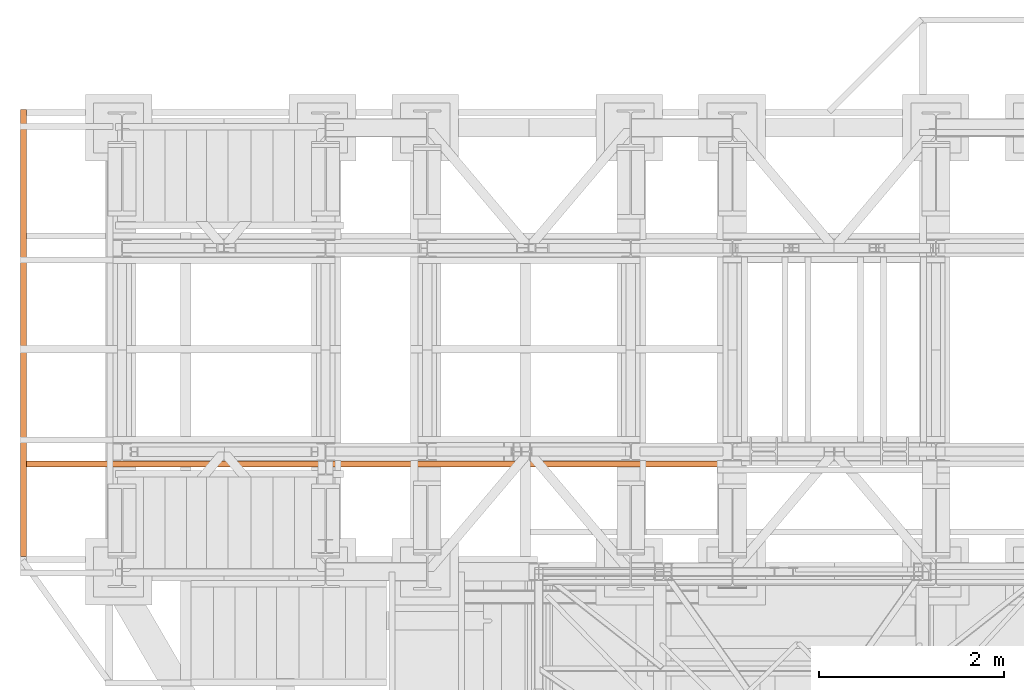
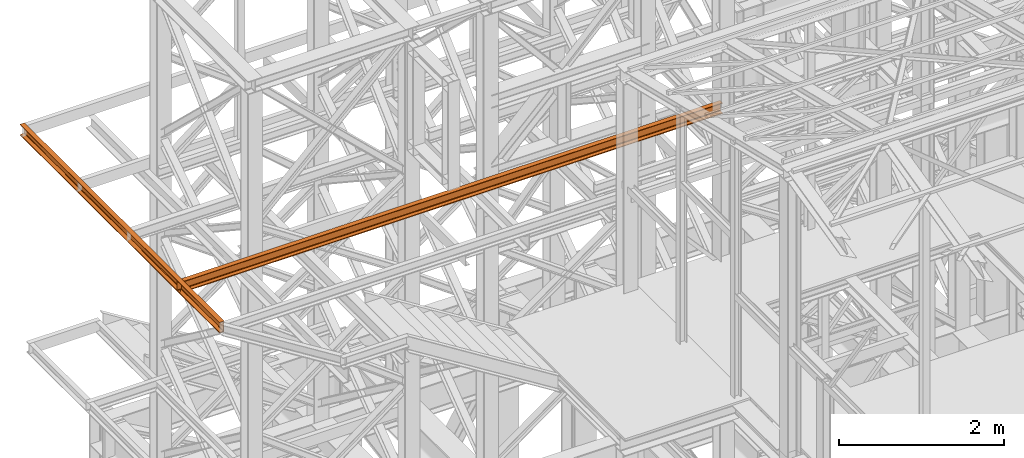
# One storey, part 92 of 208: 2 proxies.
"""IFC2X3 building model written with IfcOpenShell, lengths in millimetres."""

from ifc_helpers import new_model, entity, si_unit, converted_unit, frame, origin, origin_with_axes, place, context, subcontext, project, spatial, faceted_brep, element, save


model = new_model("IFC2X3")

# Units and contexts
model_context = context("Model", 3, precision=1e-05, world=origin())
plan_context = context("Plan", 3, precision=1e-05, world=origin())
body_context = subcontext(model_context, "Body", "Model", "MODEL_VIEW")
ifc_project = project(units=[si_unit("LENGTHUNIT", "METRE", prefix="MILLI"), converted_unit("PLANEANGLEUNIT", "DEGREE", entity("IfcPlaneAngleMeasure", 0.0174532925199433), si_unit("PLANEANGLEUNIT", "RADIAN"), dimensions=[0, 0, 0, 0, 0, 0, 0]), si_unit("AREAUNIT", "SQUARE_METRE"), si_unit("VOLUMEUNIT", "CUBIC_METRE")], contexts=[model_context, plan_context])

# Building, storey
building_placement = place(None, origin())
building = spatial("IfcBuilding", under=ifc_project, at=building_placement, CompositionType="COMPLEX")
storey_placement = place(building_placement, origin_with_axes())
storey = spatial("IfcBuildingStorey", under=building, at=storey_placement, Name="Geschoss", CompositionType="ELEMENT")

# Proxies
proxy_1_placement = place(storey_placement, frame((-4406.745032961457, -17097.574391808, 9699.989999999998), z_axis=(0.0, 0.0, 1.0), x_axis=(1.0, 0.0, 0.0)))
element("IfcBuildingElementProxy", 1, at=proxy_1_placement, inside=storey, context=body_context, shape_type="Brep", body=[
    faceted_brep([(0.01000000000021828, 4834.878890000196, 0.01000000000021828), (0.01000000000021828, 4834.878890000196, 3.132428070246533), (0.01000000000385626, 0.00999999999839929, 3.132428070246533), (0.01000000000385626, 0.00999999999839929, 0.01000000000021828), (0.01000000000021828, 4834.878890000196, 3.132428070246533), (0.2527365771729819, 4834.878890000196, 4.748288908171162), (0.2527365771784389, 0.00999999999839929, 4.748288908171162), (0.01000000000385626, 0.00999999999839929, 3.132428070246533), (0.2527365771729819, 4834.878890000196, 4.748288908171162), (0.9594677141431021, 4834.878890000196, 6.221534443444398), (0.959467714148559, 0.00999999999839929, 6.221534443444398), (0.2527365771784389, 0.00999999999839929, 4.748288908171162), (0.9594677141431021, 4834.878890000196, 6.221534443444398), (2.067848361530196, 4834.878890000196, 7.422126703873801), (2.067848361535653, 0.00999999999839929, 7.422126703873801), (0.959467714148559, 0.00999999999839929, 6.221534443444398), (2.067848361530196, 4834.878890000196, 7.422126703873801), (3.4800435885154, 4834.878890000196, 8.244091391710754), (3.480043588520857, 0.00999999999839929, 8.244091391710754), (2.067848361535653, 0.00999999999839929, 7.422126703873801), (3.4800435885154, 4834.878890000196, 8.244091391710754), (5.071401277444238, 4834.878890000196, 8.614912102195376), (5.071401277449695, 0.00999999999839929, 8.614912102195376), (3.480043588520857, 0.00999999999839929, 8.244091391710754), (5.071401277444238, 4834.878890000196, 8.614912102195376), (47.84732483397056, 4834.878890000196, 12.0369859867169), (47.8473248339742, 0.00999999999839929, 12.0369859867169), (5.071401277449695, 0.00999999999839929, 8.614912102195376), (47.84732483397056, 4834.878890000196, 12.0369859867169), (50.88537133101636, 4834.878890000196, 12.74491643400506), (50.88537133102182, 0.00999999999839929, 12.74491643400506), (47.8473248339742, 0.00999999999839929, 12.0369859867169), (50.88537133101636, 4834.878890000196, 12.74491643400506), (53.5813804007139, 4834.878890000196, 14.31412174714933), (53.58138040071754, 0.00999999999839929, 14.31412174714933), (50.88537133102182, 0.00999999999839929, 12.74491643400506), (53.5813804007139, 4834.878890000196, 14.31412174714933), (55.69737981845174, 4834.878890000196, 16.60616151705835), (55.69737981845719, 0.00999999999839929, 16.60616151705835), (53.58138040071754, 0.00999999999839929, 14.31412174714933), (55.69737981845174, 4834.878890000196, 16.60616151705835), (57.04659380721387, 4834.878890000196, 19.41872117530875), (57.04659380721932, 0.00999999999839929, 19.41872117530875), (55.69737981845719, 0.00999999999839929, 16.60616151705835), (57.04659380721387, 4834.878890000196, 19.41872117530875), (57.51000000000022, 4834.878890000196, 22.50354641134618), (57.51000000000386, 0.00999999999839929, 22.50354641134618), (57.04659380721932, 0.00999999999839929, 19.41872117530875), (57.51000000000022, 4834.878890000196, 22.50354641134618), (57.51000000000022, 4834.878890000196, 137.5164535886524), (57.51000000000386, 0.00999999999839929, 137.5164535886524), (57.51000000000386, 0.00999999999839929, 22.50354641134618), (57.51000000000022, 4834.878890000196, 137.5164535886524), (57.04659380721387, 4834.878890000196, 140.6012788246917), (57.04659380721932, 0.00999999999839929, 140.6012788246917), (57.51000000000386, 0.00999999999839929, 137.5164535886524), (57.04659380721387, 4834.878890000196, 140.6012788246917), (55.69737981845174, 4834.878890000196, 143.4138384829403), (55.69737981845719, 0.00999999999839929, 143.4138384829403), (57.04659380721932, 0.00999999999839929, 140.6012788246917), (55.69737981845174, 4834.878890000196, 143.4138384829403), (53.5813804007139, 4834.878890000196, 145.7058782528493), (53.58138040071754, 0.00999999999839929, 145.7058782528493), (55.69737981845719, 0.00999999999839929, 143.4138384829403), (53.5813804007139, 4834.878890000196, 145.7058782528493), (50.88537133101636, 4834.878890000196, 147.2750835659936), (50.88537133102182, 0.00999999999839929, 147.2750835659936), (53.58138040071754, 0.00999999999839929, 145.7058782528493), (50.88537133101636, 4834.878890000196, 147.2750835659936), (47.84732483397056, 4834.878890000196, 147.9830140132817), (47.84732483397602, 0.00999999999839929, 147.9830140132817), (50.88537133102182, 0.00999999999839929, 147.2750835659936), (47.84732483397056, 4834.878890000196, 147.9830140132817), (5.071401277444238, 4834.878890000196, 151.4050878978032), (5.071401277449695, 0.00999999999839929, 151.4050878978032), (47.84732483397602, 0.00999999999839929, 147.9830140132817), (5.071401277444238, 4834.878890000196, 151.4050878978032), (3.4800435885154, 4834.878890000196, 151.7759086082879), (3.480043588520857, 0.00999999999839929, 151.7759086082879), (5.071401277449695, 0.00999999999839929, 151.4050878978032), (3.4800435885154, 4834.878890000196, 151.7759086082879), (2.067848361530196, 4834.878890000196, 152.5978732961248), (2.067848361535653, 0.00999999999839929, 152.5978732961248), (3.480043588520857, 0.00999999999839929, 151.7759086082879), (2.067848361530196, 4834.878890000196, 152.5978732961248), (0.9594677141431021, 4834.878890000196, 153.7984655565542), (0.959467714148559, 0.00999999999839929, 153.7984655565542), (2.067848361535653, 0.00999999999839929, 152.5978732961248), (0.9594677141431021, 4834.878890000196, 153.7984655565542), (0.2527365771729819, 4834.878890000196, 155.2717110918275), (0.2527365771784389, 0.00999999999839929, 155.2717110918275), (0.959467714148559, 0.00999999999839929, 153.7984655565542), (0.2527365771729819, 4834.878890000196, 155.2717110918275), (0.01000000000021828, 4834.878890000196, 156.8875719297521), (0.01000000000385626, 0.00999999999839929, 156.8875719297521), (0.2527365771784389, 0.00999999999839929, 155.2717110918275), (0.01000000000021828, 4834.878890000196, 156.8875719297521), (0.01000000000021828, 4834.878890000196, 160.0100000000002), (0.01000000000385626, 0.00999999999839929, 160.0100000000002), (0.01000000000385626, 0.00999999999839929, 156.8875719297521), (0.01000000000021828, 4834.878890000196, 160.0100000000002), (65.01000000000022, 4834.878890000196, 160.0100000000002), (65.01000000000386, 0.00999999999839929, 160.0100000000002), (0.01000000000385626, 0.00999999999839929, 160.0100000000002), (65.01000000000022, 4834.878890000196, 160.0100000000002), (65.01000000000022, 4834.878890000196, 0.01000000000021828), (65.01000000000386, 0.00999999999839929, 0.01000000000021828), (65.01000000000386, 0.00999999999839929, 160.0100000000002), (65.01000000000022, 4834.878890000196, 0.01000000000021828), (0.01000000000021828, 4834.878890000196, 0.01000000000021828), (0.01000000000385626, 0.00999999999839929, 0.01000000000021828), (65.01000000000386, 0.00999999999839929, 0.01000000000021828), (0.01000000000021828, 4834.878890000196, 0.01000000000021828), (65.01000000000022, 4834.878890000196, 0.01000000000021828), (65.01000000000022, 4834.878890000196, 160.0100000000002), (0.01000000000021828, 4834.878890000196, 160.0100000000002), (0.01000000000021828, 4834.878890000196, 156.8875719297521), (0.2527365771729819, 4834.878890000196, 155.2717110918275), (0.9594677141431021, 4834.878890000196, 153.7984655565542), (2.067848361530196, 4834.878890000196, 152.5978732961248), (3.4800435885154, 4834.878890000196, 151.7759086082879), (5.071401277444238, 4834.878890000196, 151.4050878978032), (47.84732483397056, 4834.878890000196, 147.9830140132817), (50.88537133101636, 4834.878890000196, 147.2750835659936), (53.5813804007139, 4834.878890000196, 145.7058782528493), (55.69737981845174, 4834.878890000196, 143.4138384829403), (57.04659380721387, 4834.878890000196, 140.6012788246917), (57.51000000000022, 4834.878890000196, 137.5164535886524), (57.51000000000022, 4834.878890000196, 22.50354641134618), (57.04659380721387, 4834.878890000196, 19.41872117530875), (55.69737981845174, 4834.878890000196, 16.60616151705835), (53.5813804007139, 4834.878890000196, 14.31412174714933), (50.88537133101636, 4834.878890000196, 12.74491643400506), (47.84732483397056, 4834.878890000196, 12.0369859867169), (5.071401277444238, 4834.878890000196, 8.614912102195376), (3.4800435885154, 4834.878890000196, 8.244091391710754), (2.067848361530196, 4834.878890000196, 7.422126703873801), (0.9594677141431021, 4834.878890000196, 6.221534443444398), (0.2527365771729819, 4834.878890000196, 4.748288908171162), (0.01000000000021828, 4834.878890000196, 3.132428070246533), (0.01000000000385626, 0.00999999999839929, 0.01000000000021828), (0.01000000000385626, 0.00999999999839929, 3.132428070246533), (0.2527365771784389, 0.00999999999839929, 4.748288908171162), (0.959467714148559, 0.00999999999839929, 6.221534443444398), (2.067848361535653, 0.00999999999839929, 7.422126703873801), (3.480043588520857, 0.00999999999839929, 8.244091391710754), (5.071401277449695, 0.00999999999839929, 8.614912102195376), (47.8473248339742, 0.00999999999839929, 12.0369859867169), (50.88537133102182, 0.00999999999839929, 12.74491643400506), (53.58138040071754, 0.00999999999839929, 14.31412174714933), (55.69737981845719, 0.00999999999839929, 16.60616151705835), (57.04659380721932, 0.00999999999839929, 19.41872117530875), (57.51000000000386, 0.00999999999839929, 22.50354641134618), (57.51000000000386, 0.00999999999839929, 137.5164535886524), (57.04659380721932, 0.00999999999839929, 140.6012788246917), (55.69737981845719, 0.00999999999839929, 143.4138384829403), (53.58138040071754, 0.00999999999839929, 145.7058782528493), (50.88537133102182, 0.00999999999839929, 147.2750835659936), (47.84732483397602, 0.00999999999839929, 147.9830140132817), (5.071401277449695, 0.00999999999839929, 151.4050878978032), (3.480043588520857, 0.00999999999839929, 151.7759086082879), (2.067848361535653, 0.00999999999839929, 152.5978732961248), (0.959467714148559, 0.00999999999839929, 153.7984655565542), (0.2527365771784389, 0.00999999999839929, 155.2717110918275), (0.01000000000385626, 0.00999999999839929, 156.8875719297521), (0.01000000000385626, 0.00999999999839929, 160.0100000000002), (65.01000000000386, 0.00999999999839929, 160.0100000000002), (65.01000000000386, 0.00999999999839929, 0.01000000000021828)], [[[0, 1, 2, 3]], [[4, 5, 6, 7]], [[8, 9, 10, 11]], [[12, 13, 14, 15]], [[16, 17, 18, 19]], [[20, 21, 22, 23]], [[24, 25, 26, 27]], [[28, 29, 30, 31]], [[32, 33, 34, 35]], [[36, 37, 38, 39]], [[40, 41, 42, 43]], [[44, 45, 46, 47]], [[48, 49, 50, 51]], [[52, 53, 54, 55]], [[56, 57, 58, 59]], [[60, 61, 62, 63]], [[64, 65, 66, 67]], [[68, 69, 70, 71]], [[72, 73, 74, 75]], [[76, 77, 78, 79]], [[80, 81, 82, 83]], [[84, 85, 86, 87]], [[88, 89, 90, 91]], [[92, 93, 94, 95]], [[96, 97, 98, 99]], [[100, 101, 102, 103]], [[104, 105, 106, 107]], [[108, 109, 110, 111]], [[112, 113, 114, 115, 116, 117, 118, 119, 120, 121, 122, 123, 124, 125, 126, 127, 128, 129, 130, 131, 132, 133, 134, 135, 136, 137, 138, 139]], [[140, 141, 142, 143, 144, 145, 146, 147, 148, 149, 150, 151, 152, 153, 154, 155, 156, 157, 158, 159, 160, 161, 162, 163, 164, 165, 166, 167]]], orient=[[False], [False], [False], [False], [False], [False], [False], [False], [False], [False], [False], [False], [False], [False], [False], [False], [False], [False], [False], [False], [False], [False], [False], [False], [False], [False], [False], [False], [False], [False]]),
])
proxy_2_placement = place(storey_placement, frame((-4406.745032961453, -16127.574391808, 9699.99), z_axis=(0.0, 0.0, 1.0), x_axis=(1.0, 0.0, 0.0)))
element("IfcBuildingElementProxy", 2, at=proxy_2_placement, inside=storey, context=body_context, shape_type="Brep", body=[
    faceted_brep([(0.01000000000021828, 0.01000000000021828, 0.01000000000021828), (0.01000000000021828, 0.01000000000021828, 3.132428070246533), (7600.010000000002, 0.00999999999839929, 3.132428070246533), (7600.010000000002, 0.00999999999839929, 0.01000000000021828), (0.01000000000021828, 0.01000000000021828, 3.132428070246533), (0.01000000000021828, 0.2527365771729819, 4.748288908171162), (7600.010000000002, 0.2527365771711629, 4.748288908171162), (7600.010000000002, 0.00999999999839929, 3.132428070246533), (0.01000000000021828, 0.2527365771729819, 4.748288908171162), (0.01000000000021828, 0.9594677141431021, 6.221534443444398), (7600.010000000002, 0.9594677141412831, 6.221534443444398), (7600.010000000002, 0.2527365771711629, 4.748288908171162), (0.01000000000021828, 0.9594677141431021, 6.221534443444398), (0.01000000000021828, 2.067848361530196, 7.422126703873801), (7600.010000000002, 2.067848361528377, 7.422126703873801), (7600.010000000002, 0.9594677141412831, 6.221534443444398), (0.01000000000021828, 2.067848361530196, 7.422126703873801), (0.01000000000021828, 3.4800435885154, 8.244091391710754), (7600.010000000002, 3.480043588513581, 8.244091391710754), (7600.010000000002, 2.067848361528377, 7.422126703873801), (0.01000000000021828, 3.4800435885154, 8.244091391710754), (0.01000000000021828, 5.071401277444238, 8.614912102195376), (7600.010000000002, 5.071401277442419, 8.614912102195376), (7600.010000000002, 3.480043588513581, 8.244091391710754), (0.01000000000021828, 5.071401277444238, 8.614912102195376), (0.01000000000021828, 47.84732483397056, 12.0369859867169), (7600.010000000002, 47.84732483396874, 12.0369859867169), (7600.010000000002, 5.071401277442419, 8.614912102195376), (0.01000000000021828, 47.84732483397056, 12.0369859867169), (0.01000000000021828, 50.88537133101636, 12.74491643400506), (7600.010000000002, 50.88537133101454, 12.74491643400506), (7600.010000000002, 47.84732483396874, 12.0369859867169), (0.01000000000021828, 50.88537133101636, 12.74491643400506), (0.01000000000021828, 53.5813804007139, 14.31412174714933), (7600.010000000002, 53.58138040071208, 14.31412174714933), (7600.010000000002, 50.88537133101454, 12.74491643400506), (0.01000000000021828, 53.5813804007139, 14.31412174714933), (0.01000000000021828, 55.69737981845356, 16.60616151705835), (7600.010000000002, 55.69737981845174, 16.60616151705835), (7600.010000000002, 53.58138040071208, 14.31412174714933), (0.01000000000021828, 55.69737981845356, 16.60616151705835), (0.01000000000021828, 57.04659380721387, 19.41872117530875), (7600.010000000002, 57.04659380721205, 19.41872117530875), (7600.010000000002, 55.69737981845174, 16.60616151705835), (0.01000000000021828, 57.04659380721387, 19.41872117530875), (0.01000000000021828, 57.51000000000022, 22.50354641134618), (7600.010000000002, 57.5099999999984, 22.50354641134618), (7600.010000000002, 57.04659380721205, 19.41872117530875), (0.01000000000021828, 57.51000000000022, 22.50354641134618), (0.01000000000021828, 57.51000000000022, 137.5164535886524), (7600.010000000002, 57.5099999999984, 137.5164535886524), (7600.010000000002, 57.5099999999984, 22.50354641134618), (0.01000000000021828, 57.51000000000022, 137.5164535886524), (0.01000000000021828, 57.04659380721387, 140.6012788246917), (7600.010000000002, 57.04659380721205, 140.6012788246917), (7600.010000000002, 57.5099999999984, 137.5164535886524), (0.01000000000021828, 57.04659380721387, 140.6012788246917), (0.01000000000021828, 55.69737981845356, 143.4138384829403), (7600.010000000002, 55.69737981845174, 143.4138384829403), (7600.010000000002, 57.04659380721205, 140.6012788246917), (0.01000000000021828, 55.69737981845356, 143.4138384829403), (0.01000000000021828, 53.5813804007139, 145.7058782528493), (7600.010000000002, 53.58138040071208, 145.7058782528493), (7600.010000000002, 55.69737981845174, 143.4138384829403), (0.01000000000021828, 53.5813804007139, 145.7058782528493), (0.01000000000021828, 50.88537133101636, 147.2750835659936), (7600.010000000002, 50.88537133101454, 147.2750835659936), (7600.010000000002, 53.58138040071208, 145.7058782528493), (0.01000000000021828, 50.88537133101636, 147.2750835659936), (0.01000000000021828, 47.84732483397056, 147.9830140132817), (7600.010000000002, 47.84732483396874, 147.9830140132817), (7600.010000000002, 50.88537133101454, 147.2750835659936), (0.01000000000021828, 47.84732483397056, 147.9830140132817), (0.01000000000021828, 5.071401277444238, 151.4050878978032), (7600.010000000002, 5.071401277442419, 151.4050878978032), (7600.010000000002, 47.84732483396874, 147.9830140132817), (0.01000000000021828, 5.071401277444238, 151.4050878978032), (0.01000000000021828, 3.4800435885154, 151.7759086082879), (7600.010000000002, 3.480043588513581, 151.7759086082879), (7600.010000000002, 5.071401277442419, 151.4050878978032), (0.01000000000021828, 3.4800435885154, 151.7759086082879), (0.01000000000021828, 2.067848361530196, 152.5978732961248), (7600.010000000002, 2.067848361528377, 152.5978732961248), (7600.010000000002, 3.480043588513581, 151.7759086082879), (0.01000000000021828, 2.067848361530196, 152.5978732961248), (0.01000000000021828, 0.9594677141431021, 153.7984655565542), (7600.010000000002, 0.9594677141412831, 153.7984655565542), (7600.010000000002, 2.067848361528377, 152.5978732961248), (0.01000000000021828, 0.9594677141431021, 153.7984655565542), (0.01000000000021828, 0.2527365771729819, 155.2717110918275), (7600.010000000002, 0.2527365771711629, 155.2717110918275), (7600.010000000002, 0.9594677141412831, 153.7984655565542), (0.01000000000021828, 0.2527365771729819, 155.2717110918275), (0.01000000000021828, 0.01000000000021828, 156.8875719297521), (7600.010000000002, 0.00999999999839929, 156.8875719297521), (7600.010000000002, 0.2527365771711629, 155.2717110918275), (0.01000000000021828, 0.01000000000021828, 156.8875719297521), (0.01000000000021828, 0.01000000000021828, 160.0100000000002), (7600.010000000002, 0.00999999999839929, 160.0100000000002), (7600.010000000002, 0.00999999999839929, 156.8875719297521), (0.01000000000021828, 0.01000000000021828, 160.0100000000002), (0.01000000000021828, 65.01000000000022, 160.0100000000002), (7600.010000000002, 65.0099999999984, 160.0100000000002), (7600.010000000002, 0.00999999999839929, 160.0100000000002), (0.01000000000021828, 65.01000000000022, 160.0100000000002), (0.01000000000021828, 65.01000000000022, 0.01000000000021828), (7600.010000000002, 65.0099999999984, 0.01000000000021828), (7600.010000000002, 65.0099999999984, 160.0100000000002), (0.01000000000021828, 65.01000000000022, 0.01000000000021828), (0.01000000000021828, 0.01000000000021828, 0.01000000000021828), (7600.010000000002, 0.00999999999839929, 0.01000000000021828), (7600.010000000002, 65.0099999999984, 0.01000000000021828), (0.01000000000021828, 0.01000000000021828, 0.01000000000021828), (0.01000000000021828, 65.01000000000022, 0.01000000000021828), (0.01000000000021828, 65.01000000000022, 160.0100000000002), (0.01000000000021828, 0.01000000000021828, 160.0100000000002), (0.01000000000021828, 0.01000000000021828, 156.8875719297521), (0.01000000000021828, 0.2527365771729819, 155.2717110918275), (0.01000000000021828, 0.9594677141431021, 153.7984655565542), (0.01000000000021828, 2.067848361530196, 152.5978732961248), (0.01000000000021828, 3.4800435885154, 151.7759086082879), (0.01000000000021828, 5.071401277444238, 151.4050878978032), (0.01000000000021828, 47.84732483397056, 147.9830140132817), (0.01000000000021828, 50.88537133101636, 147.2750835659936), (0.01000000000021828, 53.5813804007139, 145.7058782528493), (0.01000000000021828, 55.69737981845356, 143.4138384829403), (0.01000000000021828, 57.04659380721387, 140.6012788246917), (0.01000000000021828, 57.51000000000022, 137.5164535886524), (0.01000000000021828, 57.51000000000022, 22.50354641134618), (0.01000000000021828, 57.04659380721387, 19.41872117530875), (0.01000000000021828, 55.69737981845356, 16.60616151705835), (0.01000000000021828, 53.5813804007139, 14.31412174714933), (0.01000000000021828, 50.88537133101636, 12.74491643400506), (0.01000000000021828, 47.84732483397056, 12.0369859867169), (0.01000000000021828, 5.071401277444238, 8.614912102195376), (0.01000000000021828, 3.4800435885154, 8.244091391710754), (0.01000000000021828, 2.067848361530196, 7.422126703873801), (0.01000000000021828, 0.9594677141431021, 6.221534443444398), (0.01000000000021828, 0.2527365771729819, 4.748288908171162), (0.01000000000021828, 0.01000000000021828, 3.132428070246533), (7600.010000000002, 0.00999999999839929, 0.01000000000021828), (7600.010000000002, 0.00999999999839929, 3.132428070246533), (7600.010000000002, 0.2527365771711629, 4.748288908171162), (7600.010000000002, 0.9594677141412831, 6.221534443444398), (7600.010000000002, 2.067848361528377, 7.422126703873801), (7600.010000000002, 3.480043588513581, 8.244091391710754), (7600.010000000002, 5.071401277442419, 8.614912102195376), (7600.010000000002, 47.84732483396874, 12.0369859867169), (7600.010000000002, 50.88537133101454, 12.74491643400506), (7600.010000000002, 53.58138040071208, 14.31412174714933), (7600.010000000002, 55.69737981845174, 16.60616151705835), (7600.010000000002, 57.04659380721205, 19.41872117530875), (7600.010000000002, 57.5099999999984, 22.50354641134618), (7600.010000000002, 57.5099999999984, 137.5164535886524), (7600.010000000002, 57.04659380721205, 140.6012788246917), (7600.010000000002, 55.69737981845174, 143.4138384829403), (7600.010000000002, 53.58138040071208, 145.7058782528493), (7600.010000000002, 50.88537133101454, 147.2750835659936), (7600.010000000002, 47.84732483396874, 147.9830140132817), (7600.010000000002, 5.071401277442419, 151.4050878978032), (7600.010000000002, 3.480043588513581, 151.7759086082879), (7600.010000000002, 2.067848361528377, 152.5978732961248), (7600.010000000002, 0.9594677141412831, 153.7984655565542), (7600.010000000002, 0.2527365771711629, 155.2717110918275), (7600.010000000002, 0.00999999999839929, 156.8875719297521), (7600.010000000002, 0.00999999999839929, 160.0100000000002), (7600.010000000002, 65.0099999999984, 160.0100000000002), (7600.010000000002, 65.0099999999984, 0.01000000000021828)], [[[0, 1, 2, 3]], [[4, 5, 6, 7]], [[8, 9, 10, 11]], [[12, 13, 14, 15]], [[16, 17, 18, 19]], [[20, 21, 22, 23]], [[24, 25, 26, 27]], [[28, 29, 30, 31]], [[32, 33, 34, 35]], [[36, 37, 38, 39]], [[40, 41, 42, 43]], [[44, 45, 46, 47]], [[48, 49, 50, 51]], [[52, 53, 54, 55]], [[56, 57, 58, 59]], [[60, 61, 62, 63]], [[64, 65, 66, 67]], [[68, 69, 70, 71]], [[72, 73, 74, 75]], [[76, 77, 78, 79]], [[80, 81, 82, 83]], [[84, 85, 86, 87]], [[88, 89, 90, 91]], [[92, 93, 94, 95]], [[96, 97, 98, 99]], [[100, 101, 102, 103]], [[104, 105, 106, 107]], [[108, 109, 110, 111]], [[112, 113, 114, 115, 116, 117, 118, 119, 120, 121, 122, 123, 124, 125, 126, 127, 128, 129, 130, 131, 132, 133, 134, 135, 136, 137, 138, 139]], [[140, 141, 142, 143, 144, 145, 146, 147, 148, 149, 150, 151, 152, 153, 154, 155, 156, 157, 158, 159, 160, 161, 162, 163, 164, 165, 166, 167]]], orient=[[False], [False], [False], [False], [False], [False], [False], [False], [False], [False], [False], [False], [False], [False], [False], [False], [False], [False], [False], [False], [False], [False], [False], [False], [False], [False], [False], [False], [False], [False]]),
])

save(model, "model.ifc")
